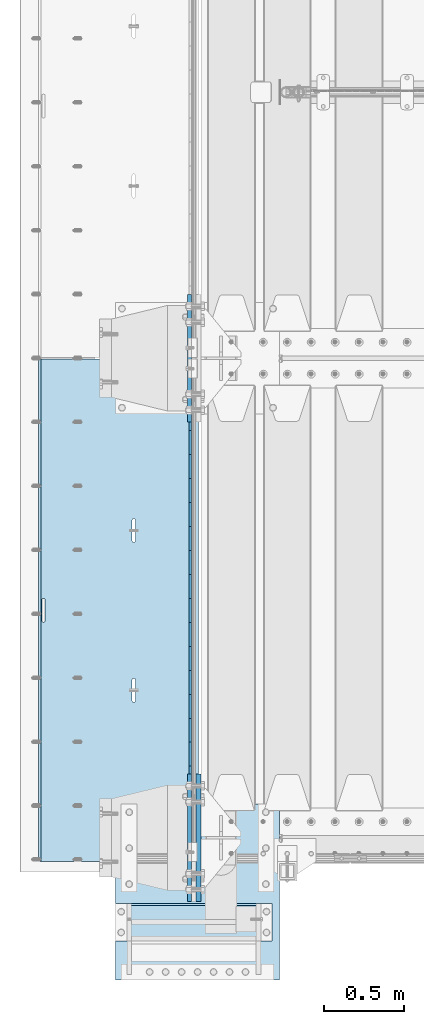
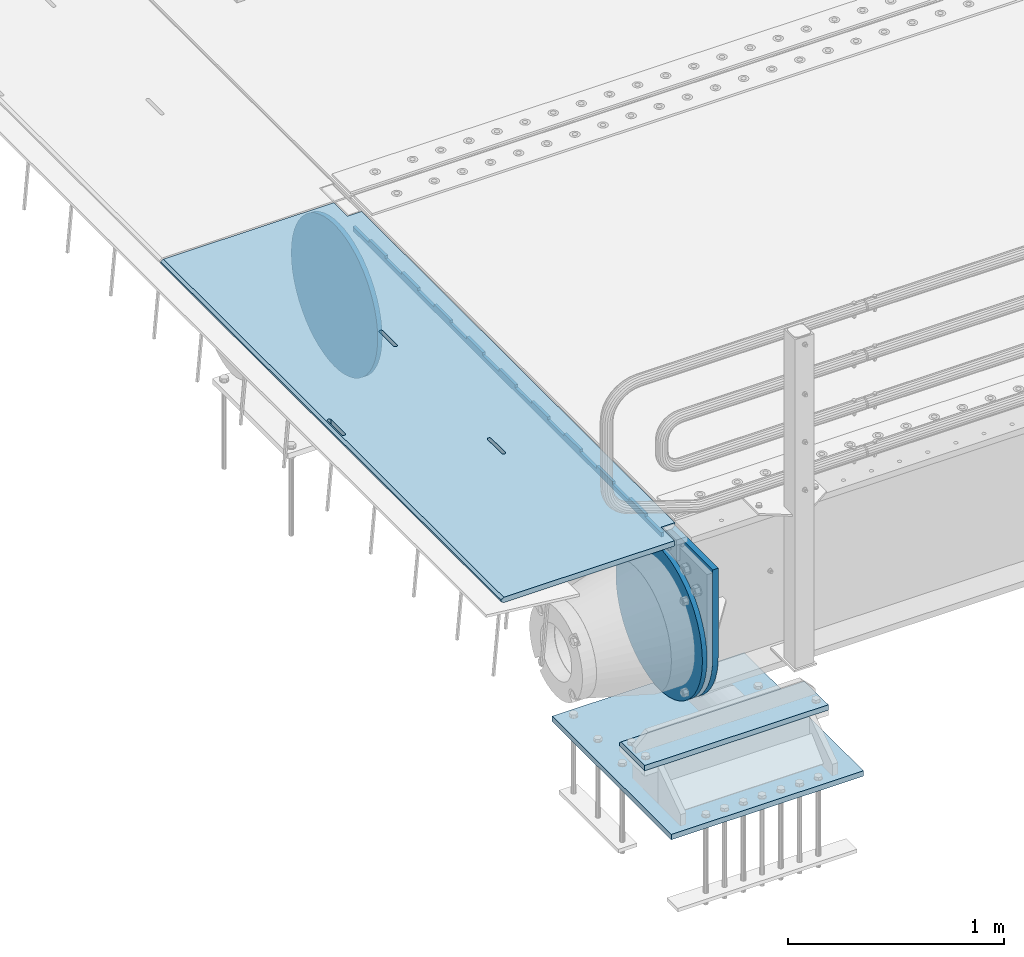
# One storey, part 190 of 242: 7 plates.
"""IFC2X3 building model written with IfcOpenShell, lengths in millimetres."""

from ifc_helpers import new_model, si_unit, frame, origin_with_axes, place, context, subcontext, project, spatial, faceted_brep, material, type_object, element, save


model = new_model("IFC2X3")

# Units and contexts
model_context = context("Model", 3, precision=1e-05, world=origin_with_axes())
body_context = subcontext(model_context, "Body", "Model", "MODEL_VIEW")
ifc_project = project(units=[si_unit("LENGTHUNIT", "METRE", prefix="MILLI"), si_unit("AREAUNIT", "SQUARE_METRE"), si_unit("VOLUMEUNIT", "CUBIC_METRE"), si_unit("MASSUNIT", "GRAM", prefix="KILO"), si_unit("TIMEUNIT", "SECOND"), si_unit("PLANEANGLEUNIT", "RADIAN"), si_unit("SOLIDANGLEUNIT", "STERADIAN"), si_unit("THERMODYNAMICTEMPERATUREUNIT", "DEGREE_CELSIUS"), si_unit("LUMINOUSINTENSITYUNIT", "LUMEN")], contexts=[model_context])

# Site, building, storey
site_placement = place(None, origin_with_axes())
site = spatial("IfcSite", under=ifc_project, at=site_placement, CompositionType="ELEMENT")
building_placement = place(site_placement, origin_with_axes())
building = spatial("IfcBuilding", under=site, at=building_placement, Name="Standard", CompositionType="ELEMENT")
storey_placement = place(building_placement, origin_with_axes())
storey = spatial("IfcBuildingStorey", under=building, at=storey_placement, Name="Undefined", CompositionType="ELEMENT", Elevation=0.0)

# Plates
ifc_material_1 = material(Name="STEEL/S355N")
plate_type_1 = type_object("IfcPlateType", PredefinedType="NOTDEFINED")
plate_1_placement = place(storey_placement, frame((-42455.0037545707, -21005.0000738707, -0.984410850183148), z_axis=(1.0000003385235e-09, -0.999999999987744, -4.95099999993936e-06), x_axis=(-0.999999999879068, -1.00000022173606e-09, -1.55519999981193e-05)))
element("IfcPlate", 1, at=plate_1_placement, inside=storey, type_object=plate_type_1, material=ifc_material_1, context=body_context, shape_type="Brep", body=[
    faceted_brep([(984.99645996136, -15.0, 3.63797880709171e-12), (999.996459960938, -4.99999999999848, 0.0), (999.996459718786, -4.99999999999849, 3145.0), (984.996459719208, -15.0, 3145.0), (999.996459960938, 5.0, 0.0), (984.996459960945, 15.0, 3.63797880709171e-12), (984.996459718794, 15.0, 3145.0), (999.996459718786, 5.0, 3145.0), (14.9998601691696, 15.0, 125.000024820823), (-0.000294611323624849, -0.000806902962788264, 124.999936248623), (-0.00191941575758392, 0.000806844426834791, 3020.00000492302), (14.9966216875182, 15.0, 3020.00007976651), (394.996621756989, -15.0000000032171, 2137.49999999762), (394.996621756989, 15.0, 2137.49999999762), (395.4860565938, 15.0, 2140.59016994137), (395.4860565938, -15.0000000032097, 2140.59016994137), (396.906451812785, 15.0, 2143.37785252055), (396.906451812785, -15.0000000031847, 2143.37785252055), (399.118769233435, 15.0, 2145.59016994137), (399.118769233435, -15.0000000031445, 2145.59016994137), (401.906451812501, 15.0, 2147.01056516057), (401.906451812509, -15.0000000030931, 2147.01056516058), (404.996621756211, 15.0, 2147.49999999762), (404.996621756211, -15.0000000030354, 2147.49999999762), (408.0867917, 15.0, 2147.01056516057), (408.0867917, -15.0000000029771, 2147.01056516058), (410.874474279284, 15.0, 2145.59016994137), (410.874474279277, -15.000000002924, 2145.59016994137), (413.086791700283, 15.0, 2143.37785252055), (413.086791700283, -15.0000000028812, 2143.37785252055), (414.507186919691, 15.0, 2140.59016994136), (414.507186919698, -15.0000000028529, 2140.59016994136), (414.996621756974, 15.0, 2137.49999999761), (414.996621756974, -15.000000002842, 2137.49999999761), (414.996621766892, 15.0, 2007.49999999761), (414.996621766892, -15.0000000027658, 2007.49999999761), (414.507186930081, 15.0, 2004.40983005386), (414.507186930088, -15.0000000027732, 2004.40983005387), (413.086791711095, 15.0, 2001.62214747469), (413.086791711088, -15.0000000027982, 2001.6221474747), (410.874474290446, 15.0, 1999.40983005387), (410.874474290438, -15.0000000028384, 1999.40983005387), (408.086791711372, 15.0, 1997.98943483467), (408.086791711372, -15.0000000028898, 1997.98943483467), (404.996621767779, 15.0, 1997.49999999762), (404.996621767779, -15.0000000029475, 1997.49999999762), (401.906451823983, 15.0, 1997.98943483467), (401.90645182399, -15.0000000030057, 1997.98943483468), (399.118769244706, 15.0, 1999.40983005387), (399.118769244713, -15.0000000030589, 1999.40983005387), (396.906451823714, 15.0, 2001.6221474747), (396.906451823714, -15.0000000031016, 2001.6221474747), (395.486056604299, 15.0, 2004.40983005387), (395.486056604299, -15.0000000031299, 2004.40983005387), (394.996621767008, 15.0, 2007.49999999762), (394.996621767008, -15.0000000031409, 2007.49999999762), (-0.000449375176685862, -14.9999999951863, 124.999861417735), (-0.000460362061858177, -15.00000004538, 3019.99993008589), (75.0001087167111, 15.0, 125.000079754092), (74.9996421867036, -15.0, 124.999930084094), (74.9997820616045, -15.0, 3.63797880709171e-12), (75.0002485915975, 15.0, 0.0), (74.9967306510152, 15.0, 3145.0), (74.9962640910162, -15.0, 3145.0), (74.9968705259016, 15.0, 3020.0000798241), (74.9964039659026, -14.999999998652, 3019.9999301541), (395.486056681293, -14.9999999992789, 1004.40983005436), (395.486056681293, 15.0, 1004.40983005435), (394.99662184401, 15.0, 1007.4999999981), (394.99662184401, -14.999999999278, 1007.49999999811), (396.906451900715, -14.999999999282, 1001.62214747518), (396.906451900715, 15.0, 1001.62214747518), (399.118769321707, -14.9999999992871, 999.409830054356), (399.1187693217, 15.0, 999.409830054356), (401.906451900999, -14.9999999992934, 997.989434835155), (401.906451900992, 15.0, 997.989434835155), (404.996621844781, -14.9999999993006, 997.499999998108), (404.996621844781, 15.0, 997.499999998108), (408.086791788373, -14.9999999993078, 997.989434835155), (408.086791788373, 15.0, 997.989434835152), (410.87447436744, -14.9999999993143, 999.409830054356), (410.87447436744, 15.0, 999.409830054356), (413.086791788097, -14.9999999993196, 1001.62214747518), (413.086791788097, 15.0, 1001.62214747518), (414.50718700709, -14.999999999323, 1004.40983005435), (414.507187007082, 15.0, 1004.40983005435), (414.996621843893, -14.9999999993243, 1007.4999999981), (414.996621843893, 15.0, 1007.4999999981), (414.996621833976, -14.9999999993318, 1137.4999999981), (414.996621833976, 15.0, 1137.49999999809), (414.507186996707, -14.9999999993308, 1140.59016994185), (414.5071869967, 15.0, 1140.59016994185), (413.086791777278, -14.9999999993277, 1143.37785252103), (413.086791777278, 15.0, 1143.37785252103), (410.874474356286, -14.9999999993227, 1145.59016994186), (410.874474356286, 15.0, 1145.59016994186), (408.086791776994, -14.9999999993163, 1147.01056516106), (408.086791776994, 15.0, 1147.01056516106), (404.996621833212, -14.9999999993092, 1147.49999999811), (404.996621833212, 15.0, 1147.4999999981), (401.90645188951, -14.999999999302, 1147.01056516106), (401.906451889503, 15.0, 1147.01056516106), (399.118769310437, -14.9999999992955, 1145.59016994186), (399.118769310437, 15.0, 1145.59016994186), (396.906451889779, -14.9999999992902, 1143.37785252103), (396.906451889779, 15.0, 1143.37785252103), (395.486056670801, -14.9999999992867, 1140.59016994185), (395.486056670808, 15.0, 1140.59016994185), (394.996621833991, -14.9999999992854, 1137.49999999811), (394.996621833998, 15.0, 1137.4999999981), (960.486056632304, -15.0000000006253, 1640.5901699416), (961.90645185129, -15.0000000006287, 1643.37785252078), (964.118769271947, -15.000000000634, 1645.5901699416), (966.906451851013, -15.0000000006405, 1647.0105651608), (969.996621794708, -15.0000000006477, 1647.49999999785), (973.086791738504, -15.0000000006549, 1647.01056516081), (975.874474317789, -15.0000000006612, 1645.5901699416), (978.086791738788, -15.0000000006662, 1643.37785252077), (979.50718695821, -15.0000000006694, 1640.5901699416), (979.996621795486, -15.0000000006703, 1637.49999999784), (979.996621805403, -15.0000000006628, 1507.49999999784), (979.507186968593, -15.0000000006615, 1504.4098300541), (978.0867917496, -15.0000000006581, 1501.62214747492), (975.874474328943, -15.0000000006528, 1499.4098300541), (973.086791749884, -15.0000000006463, 1497.9894348349), (969.996621806284, -15.0000000006391, 1497.49999999785), (966.906451862502, -15.0000000006319, 1497.9894348349), (964.118769283217, -15.0000000006256, 1499.4098300541), (961.906451862218, -15.0000000006206, 1501.62214747493), (960.486056642803, -15.0000000006174, 1504.4098300541), (959.99662180552, -15.0000000006165, 1507.49999999785), (959.996621795493, -15.000000000624, 1637.49999999785), (961.906451862218, 15.0, 1501.62214747493), (960.486056642803, 15.0, 1504.4098300541), (964.11876928321, 15.0, 1499.4098300541), (966.906451862495, 15.0, 1497.9894348349), (969.996621806284, 15.0, 1497.49999999785), (973.086791749884, 15.0, 1497.9894348349), (975.874474328943, 15.0, 1499.4098300541), (978.0867917496, 15.0, 1501.62214747492), (979.507186968585, 15.0, 1504.4098300541), (979.996621805403, 15.0, 1507.49999999784), (979.996621795486, 15.0, 1637.49999999784), (979.507186958203, 15.0, 1640.5901699416), (978.086791738788, 15.0, 1643.37785252077), (975.874474317789, 15.0, 1645.5901699416), (973.086791738504, 15.0, 1647.01056516081), (969.996621794715, 15.0, 1647.49999999785), (966.906451851006, 15.0, 1647.0105651608), (964.118769271947, 15.0, 1645.5901699416), (961.90645185129, 15.0, 1643.37785252078), (960.486056632304, 15.0, 1640.5901699416), (959.996621795493, 15.0, 1637.49999999785), (959.99662180552, 15.0, 1507.49999999785)], [[[0, 1, 2, 3]], [[4, 5, 6, 7]], [[8, 9, 10, 11]], [[12, 13, 14, 15]], [[15, 14, 16, 17]], [[17, 16, 18, 19]], [[19, 18, 20, 21]], [[21, 20, 22, 23]], [[23, 22, 24, 25]], [[25, 24, 26, 27]], [[27, 26, 28, 29]], [[29, 28, 30, 31]], [[31, 30, 32, 33]], [[33, 32, 34, 35]], [[35, 34, 36, 37]], [[37, 36, 38, 39]], [[39, 38, 40, 41]], [[41, 40, 42, 43]], [[43, 42, 44, 45]], [[45, 44, 46, 47]], [[47, 46, 48, 49]], [[49, 48, 50, 51]], [[51, 50, 52, 53]], [[53, 52, 54, 55]], [[55, 54, 13, 12]], [[56, 57, 10, 9]], [[58, 59, 56, 9, 8]], [[60, 59, 58, 61]], [[60, 61, 5, 4, 1, 0]], [[4, 7, 2, 1]], [[7, 6, 62, 63, 3, 2]], [[63, 62, 64, 65]], [[57, 65, 64, 11, 10]], [[66, 67, 68, 69]], [[70, 71, 67, 66]], [[72, 73, 71, 70]], [[74, 75, 73, 72]], [[76, 77, 75, 74]], [[78, 79, 77, 76]], [[80, 81, 79, 78]], [[82, 83, 81, 80]], [[84, 85, 83, 82]], [[86, 87, 85, 84]], [[88, 89, 87, 86]], [[90, 91, 89, 88]], [[92, 93, 91, 90]], [[94, 95, 93, 92]], [[96, 97, 95, 94]], [[98, 99, 97, 96]], [[100, 101, 99, 98]], [[102, 103, 101, 100]], [[104, 105, 103, 102]], [[106, 107, 105, 104]], [[108, 109, 107, 106]], [[69, 68, 109, 108]], [[63, 65, 57, 56, 59, 60, 0, 3], [15, 17, 19, 21, 23, 25, 27, 29, 31, 33, 35, 37, 39, 41, 43, 45, 47, 49, 51, 53, 55, 12], [106, 104, 102, 100, 98, 96, 94, 92, 90, 88, 86, 84, 82, 80, 78, 76, 74, 72, 70, 66, 69, 108], [110, 111, 112, 113, 114, 115, 116, 117, 118, 119, 120, 121, 122, 123, 124, 125, 126, 127, 128, 129, 130, 131]], [[128, 132, 133, 129]], [[127, 134, 132, 128]], [[126, 135, 134, 127]], [[125, 136, 135, 126]], [[124, 137, 136, 125]], [[123, 138, 137, 124]], [[122, 139, 138, 123]], [[121, 140, 139, 122]], [[120, 141, 140, 121]], [[119, 142, 141, 120]], [[118, 143, 142, 119]], [[117, 144, 143, 118]], [[116, 145, 144, 117]], [[115, 146, 145, 116]], [[114, 147, 146, 115]], [[113, 148, 147, 114]], [[112, 149, 148, 113]], [[111, 150, 149, 112]], [[110, 151, 150, 111]], [[131, 152, 151, 110]], [[130, 153, 152, 131]], [[129, 133, 153, 130]], [[61, 58, 8, 11, 64, 62, 6, 5], [50, 48, 46, 44, 42, 40, 38, 36, 34, 32, 30, 28, 26, 24, 22, 20, 18, 16, 14, 13, 54, 52], [132, 134, 135, 136, 137, 138, 139, 140, 141, 142, 143, 144, 145, 146, 147, 148, 149, 150, 151, 152, 153, 133], [71, 73, 75, 77, 79, 81, 83, 85, 87, 89, 91, 93, 95, 97, 99, 101, 103, 105, 107, 109, 68, 67]]]),
])
plate_type_2 = type_object("IfcPlateType", PredefinedType="NOTDEFINED")
plate_2_placement = place(storey_placement, frame((-42507.5, -21152.4999006275, -35.9858217390411), z_axis=(1.0000003385235e-09, -0.999999999987744, -4.95099999993936e-06), x_axis=(0.0, 4.95100000930962e-06, -0.999999999987744)))
element("IfcPlate", 2, at=plate_2_placement, inside=storey, type_object=plate_type_2, material=ifc_material_1, context=body_context, shape_type="Brep", body=[
    faceted_brep([(-7.105427357601e-15, -7.5, 3.63797880709171e-12), (8.68283223098842e-12, -7.5, 150.000000000004), (8.68283223098842e-12, 7.5, 150.000000000004), (-7.105427357601e-15, 7.5, 3.63797880709171e-12), (-14.9999999999986, -7.5, 150.0), (-14.9999999999986, 7.5, 150.0), (-14.9999999999972, -7.5, 300.000000000004), (-14.9999999999972, 7.5, 300.000000000004), (1.55324642037158e-11, -7.5, 300.000000000004), (1.55324642037158e-11, 7.5, 300.000000000004), (1.87654336514242e-11, -7.5, 450.000000000004), (1.87654336514242e-11, 7.5, 450.000000000004), (-14.9999999999958, -7.5, 450.000000000004), (-14.9999999999958, 7.5, 450.000000000004), (-14.9999999999944, -7.5, 600.0), (-14.9999999999944, 7.5, 600.0), (2.74411604550551e-11, -7.5, 600.000000000004), (2.74411604550551e-11, 7.5, 600.000000000004), (3.24860138789518e-11, -7.5, 750.000000000004), (3.24860138789518e-11, 7.5, 750.000000000004), (-14.999999999993, -7.5, 750.000000000004), (-14.999999999993, 7.5, 750.000000000004), (-14.9999999999916, -7.5, 900.000000000007), (-14.9999999999916, 7.5, 900.000000000007), (4.11688461099402e-11, -7.5, 900.000000000004), (4.11688461099402e-11, 7.5, 900.000000000004), (4.62136995338369e-11, -7.5, 1050.0), (4.62136995338369e-11, 7.5, 1050.0), (-14.9999999999902, -7.5, 1050.0), (-14.9999999999902, 7.5, 1050.0), (-14.9999999999888, -7.5, 1200.0), (-14.9999999999888, 7.5, 1200.0), (5.30775423612795e-11, -7.5, 1200.0), (5.30775423612795e-11, 7.5, 1200.0), (5.99413851887221e-11, -7.5, 1350.0), (5.99413851887221e-11, 7.5, 1350.0), (-14.9999999999874, -7.5, 1350.00000000001), (-14.9999999999874, 7.5, 1350.00000000001), (-14.9999999999859, -7.5, 1500.0), (-14.9999999999859, 7.5, 1500.0), (6.49791331852612e-11, -7.5, 1500.0), (6.49791331852612e-11, 7.5, 1500.0), (7.36690708436072e-11, -7.5, 1650.0), (7.36690708436072e-11, 7.5, 1650.0), (-14.9999999999845, -7.5, 1650.0), (-14.9999999999845, 7.5, 1650.0), (-14.9999999999831, -7.5, 1800.00000000001), (-14.9999999999831, 7.5, 1800.00000000001), (7.68878294366004e-11, -7.5, 1800.0), (7.68878294366004e-11, 7.5, 1800.0), (8.3751672264043e-11, -7.5, 1950.0), (8.3751672264043e-11, 7.5, 1950.0), (-14.9999999999817, -7.5, 1950.0), (-14.9999999999817, 7.5, 1950.0), (-14.9999999999803, -7.5, 2100.0), (-14.9999999999803, 7.5, 2100.0), (9.06226205188432e-11, -7.5, 2100.0), (9.06226205188432e-11, 7.5, 2100.0), (9.56603685153823e-11, -7.5, 2250.00000000001), (9.56603685153823e-11, 7.5, 2250.00000000001), (-14.9999999999789, -7.5, 2250.00000000001), (-14.9999999999789, 7.5, 2250.00000000001), (-14.9999999999775, -7.5, 2400.0), (-14.9999999999775, 7.5, 2400.0), (1.04343200746371e-10, -7.5, 2400.0), (1.04343200746371e-10, 7.5, 2400.0), (1.0938094874291e-10, -7.5, 2550.0), (1.0938094874291e-10, 7.5, 2550.0), (-14.9999999999761, -7.5, 2550.0), (-14.9999999999761, 7.5, 2550.0), (-14.9999999999747, -7.5, 2700.00000000001), (-14.9999999999747, 7.5, 2700.00000000001), (1.14432907594164e-10, -7.5, 2700.00000000001), (1.14432907594164e-10, 7.5, 2700.00000000001), (1.23108634397795e-10, -7.5, 2850.0), (1.23108634397795e-10, 7.5, 2850.0), (25.0000000000267, -7.5, 2850.0), (25.0000000000267, 7.5, 2850.0), (25.0, -7.5, 3.63797880709171e-12), (25.0, 7.5, 3.63797880709171e-12)], [[[0, 1, 2, 3]], [[1, 4, 5, 2]], [[4, 6, 7, 5]], [[6, 8, 9, 7]], [[8, 10, 11, 9]], [[10, 12, 13, 11]], [[12, 14, 15, 13]], [[14, 16, 17, 15]], [[16, 18, 19, 17]], [[18, 20, 21, 19]], [[20, 22, 23, 21]], [[22, 24, 25, 23]], [[24, 26, 27, 25]], [[26, 28, 29, 27]], [[28, 30, 31, 29]], [[30, 32, 33, 31]], [[32, 34, 35, 33]], [[34, 36, 37, 35]], [[36, 38, 39, 37]], [[38, 40, 41, 39]], [[40, 42, 43, 41]], [[42, 44, 45, 43]], [[44, 46, 47, 45]], [[46, 48, 49, 47]], [[48, 50, 51, 49]], [[50, 52, 53, 51]], [[52, 54, 55, 53]], [[54, 56, 57, 55]], [[56, 58, 59, 57]], [[58, 60, 61, 59]], [[60, 62, 63, 61]], [[62, 64, 65, 63]], [[64, 66, 67, 65]], [[66, 68, 69, 67]], [[68, 70, 71, 69]], [[70, 72, 73, 71]], [[72, 74, 75, 73]], [[74, 76, 77, 75]], [[76, 78, 79, 77]], [[78, 0, 3, 79]], [[5, 7, 9, 11, 13, 15, 17, 19, 21, 23, 25, 27, 29, 31, 33, 35, 37, 39, 41, 43, 45, 47, 49, 51, 53, 55, 57, 59, 61, 63, 65, 67, 69, 71, 73, 75, 77, 79, 3, 2]], [[78, 76, 74, 72, 70, 68, 66, 64, 62, 60, 58, 56, 54, 52, 50, 48, 46, 44, 42, 40, 38, 36, 34, 32, 30, 28, 26, 24, 22, 20, 18, 16, 14, 12, 10, 8, 6, 4, 1, 0]]]),
])
plate_type_3 = type_object("IfcPlateType", PredefinedType="NOTDEFINED")
plate_3_placement = place(storey_placement, frame((-42455.0, -24400.0, -20.0), z_axis=(0.0, 1.0, 0.0), x_axis=(0.0, 0.0, -1.0)))
element("IfcPlate", 3, at=plate_3_placement, inside=storey, type_object=plate_type_3, material=ifc_material_1, context=body_context, shape_type="Brep", body=[
    faceted_brep([(855.0, -15.0, 572.963114670041), (855.0, 15.0, 572.963114670041), (849.182410260924, 15.0, 585.889268816907), (849.182410260924, -15.0, 585.889268816907), (824.193546357181, 15.0, 627.22589869189), (824.193546357181, -15.0, 627.22589869189), (794.404299268241, 15.0, 665.249063295789), (794.404299268241, -15.0, 665.249063295789), (760.249063296205, 15.0, 699.404299267968), (760.249063296205, -15.0, 699.404299267968), (722.225898692439, 15.0, 729.193546357052), (722.225898692439, -15.0, 729.193546357052), (680.889268817575, 15.0, 754.182410260939), (680.889268817575, -15.0, 754.182410260939), (636.841954817181, 15.0, 774.006497073897), (636.841954817181, -15.0, 774.006497073897), (590.726265715288, 15.0, 788.376726970229), (590.726265715288, -15.0, 788.376726970229), (543.214672102496, 15.0, 797.083549639108), (543.214672102496, -15.0, 797.083549639108), (495.0, -15.0, 800.000000000029), (495.0, 15.0, 800.0), (494.999999999412, -15.0, 0.0), (494.999999999412, 15.0, 0.0), (543.21467210319, 15.0, 2.91645036481714), (543.21467210319, -15.0, 2.91645036481714), (590.726265715857, 15.0, 11.6232730332849), (590.726265715857, -15.0, 11.6232730332849), (636.841954817646, 15.0, 25.9935029291846), (636.841954817646, -15.0, 25.9935029291846), (680.889268817962, 15.0, 45.817589741695), (680.889268817962, -15.0, 45.817589741695), (722.225898692766, 15.0, 70.8064536451311), (722.225898692766, -15.0, 70.8064536451311), (760.249063296498, 15.0, 100.595700733757), (760.249063296498, -15.0, 100.595700733757), (794.404299268526, 15.0, 134.750936705481), (794.404299268526, -15.0, 134.750936705481), (824.193546357479, 15.0, 172.77410130894), (824.193546357479, -15.0, 172.77410130894), (849.182410261259, 15.0, 214.110731183497), (849.182410261259, -15.0, 214.110731183497), (855.0, -15.0, 227.03688532946), (855.0, 15.0, 227.03688532946), (0.0, -15.0, 0.0), (0.0, 15.0, 0.0), (0.0, 15.0, 800.0), (0.0, -15.0, 800.0)], [[[0, 1, 2, 3]], [[3, 2, 4, 5]], [[5, 4, 6, 7]], [[7, 6, 8, 9]], [[9, 8, 10, 11]], [[11, 10, 12, 13]], [[13, 12, 14, 15]], [[15, 14, 16, 17]], [[17, 16, 18, 19]], [[20, 19, 18, 21]], [[22, 23, 24, 25]], [[25, 24, 26, 27]], [[27, 26, 28, 29]], [[29, 28, 30, 31]], [[31, 30, 32, 33]], [[33, 32, 34, 35]], [[35, 34, 36, 37]], [[37, 36, 38, 39]], [[39, 38, 40, 41]], [[42, 41, 40, 43]], [[42, 43, 1, 0]], [[44, 45, 23, 22]], [[16, 14, 12, 10, 8, 6, 4, 2, 1, 43, 40, 38, 36, 34, 32, 30, 28, 26, 24, 23, 45, 46, 21, 18]], [[44, 47, 46, 45]], [[46, 47, 20, 21]], [[47, 44, 22, 25, 27, 29, 31, 33, 35, 37, 39, 41, 42, 0, 3, 5, 7, 9, 11, 13, 15, 17, 19, 20]]]),
])
plate_type_4 = type_object("IfcPlateType", PredefinedType="NOTDEFINED")
plate_4_placement = place(storey_placement, frame((-42512.5, -20600.0, -114.999999999998), z_axis=(0.0, 0.0, -1.0), x_axis=(0.0, -1.0, 0.0)))
element("IfcPlate", 4, at=plate_4_placement, inside=storey, type_object=plate_type_4, material=ifc_material_1, context=body_context, shape_type="Brep", body=[
    faceted_brep([(0.0, -12.5, 400.0), (2.91645036199043, -12.5, 448.214672101509), (2.91645036199043, 12.5, 448.214672101509), (0.0, 12.5, 400.0), (11.6232730309493, -12.5, 495.726265714256), (11.6232730309493, 12.5, 495.726265714256), (25.9935029273402, -12.5, 541.841954816098), (25.9935029273402, 12.5, 541.841954816098), (45.8175897403271, -12.5, 585.889268816447), (45.8175897403271, 12.5, 585.889268816447), (70.8064536442362, -12.5, 627.225898691268), (70.8064536442362, 12.5, 627.225898691268), (100.595700733313, -12.5, 665.249063295001), (100.595700733313, 12.5, 665.249063295001), (134.75093670547, -12.5, 699.404299267018), (134.75093670547, 12.5, 699.404299267018), (172.774101309336, -12.5, 729.193546355957), (172.774101309336, 12.5, 729.193546355957), (214.110731184279, -12.5, 754.182410259717), (214.110731184279, 12.5, 754.182410259717), (258.158045184744, -12.5, 774.006497072562), (258.158045184744, 12.5, 774.006497072562), (304.273734286689, -12.5, 788.376726968807), (304.273734286689, 12.5, 788.376726968807), (351.785327899524, -12.5, 797.083549637626), (351.785327899524, 12.5, 797.083549637626), (400.0, -12.5, 800.0), (400.0, 12.5, 800.0), (448.214672103393, -12.5, 797.083549638417), (448.214672103393, 12.5, 797.083549638417), (495.726265716065, -12.5, 788.376726969676), (495.726265716065, 12.5, 788.376726969676), (541.841954817828, -12.5, 774.006497073487), (541.841954817828, 12.5, 774.006497073487), (585.889268818089, -12.5, 754.182410260677), (585.889268818089, 12.5, 754.182410260677), (627.225898692814, -12.5, 729.193546356937), (627.225898692814, 12.5, 729.193546356937), (665.249063296429, -12.5, 699.404299268004), (665.249063296429, 12.5, 699.404299268004), (699.404299268321, -12.5, 665.249063295974), (699.404299268321, 12.5, 665.249063295974), (729.19354635711, -12.5, 627.225898692221), (729.19354635711, 12.5, 627.225898692221), (754.182410260706, -12.5, 585.889268817375), (754.182410260706, 12.5, 585.889268817375), (774.006497073366, -12.5, 541.841954817), (774.006497073366, 12.5, 541.841954817), (788.376726969411, -12.5, 495.726265715133), (788.376726969411, 12.5, 495.726265715133), (797.08354963801, -12.5, 448.214672102373), (797.08354963801, 12.5, 448.214672102373), (800.0, -12.5, 400.0), (800.0, 12.5, 400.0), (797.08354963802, -12.5, 351.785327898509), (797.08354963802, 12.5, 351.785327898509), (788.376726969058, -12.5, 304.273734285764), (788.376726969058, 12.5, 304.273734285764), (774.006497072671, -12.5, 258.158045183922), (774.006497072671, 12.5, 258.158045183922), (754.18241025968, -12.5, 214.110731183573), (754.18241025968, 12.5, 214.110731183573), (729.193546355775, -12.5, 172.774101308758), (729.193546355775, 12.5, 172.774101308758), (699.404299266695, -12.5, 134.750936705022), (699.404299266695, 12.5, 134.750936705022), (665.249063294537, -12.5, 100.595700733011), (665.249063294537, 12.5, 100.595700733011), (627.225898690671, -12.5, 70.8064536440761), (627.225898690671, 12.5, 70.8064536440761), (585.889268815728, -12.5, 45.817589740318), (585.889268815728, 12.5, 45.817589740318), (541.841954815267, -12.5, 25.9935029274748), (541.841954815267, 12.5, 25.9935029274748), (495.726265713321, -12.5, 11.6232730312331), (495.726265713321, 12.5, 11.6232730312331), (448.214672100487, -12.5, 2.91645036241607), (448.214672100487, 12.5, 2.91645036241607), (400.0, -12.5, -5.6843418860808e-14), (400.0, 12.5, -5.6843418860808e-14), (351.785327896621, -12.5, 2.91645036159753), (351.785327896621, 12.5, 2.91645036159753), (304.27373428395, -12.5, 11.6232730303418), (304.27373428395, 12.5, 11.6232730303418), (258.15804518219, -12.5, 25.9935029265289), (258.15804518219, 12.5, 25.9935029265289), (214.110731181929, -12.5, 45.8175897393394), (214.110731181929, 12.5, 45.8175897393394), (172.774101307208, -12.5, 70.8064536430811), (172.774101307208, 12.5, 70.8064536430811), (134.750936703589, -12.5, 100.595700732014), (134.750936703589, 12.5, 100.595700732014), (100.595700731697, -12.5, 134.750936704046), (100.595700731697, 12.5, 134.750936704046), (70.8064536429083, -12.5, 172.774101307798), (70.8064536429083, 12.5, 172.774101307798), (45.8175897393157, -12.5, 214.11073118264), (45.8175897393157, 12.5, 214.11073118264), (25.9935029266562, -12.5, 258.158045183016), (25.9935029266562, 12.5, 258.158045183016), (11.623273030611, -12.5, 304.273734284881), (11.623273030611, 12.5, 304.273734284881), (2.91645036201226, -12.5, 351.785327897642), (2.91645036201226, 12.5, 351.785327897642)], [[[0, 1, 2, 3]], [[1, 4, 5, 2]], [[4, 6, 7, 5]], [[6, 8, 9, 7]], [[8, 10, 11, 9]], [[10, 12, 13, 11]], [[12, 14, 15, 13]], [[14, 16, 17, 15]], [[16, 18, 19, 17]], [[18, 20, 21, 19]], [[20, 22, 23, 21]], [[22, 24, 25, 23]], [[24, 26, 27, 25]], [[26, 28, 29, 27]], [[28, 30, 31, 29]], [[30, 32, 33, 31]], [[32, 34, 35, 33]], [[34, 36, 37, 35]], [[36, 38, 39, 37]], [[38, 40, 41, 39]], [[40, 42, 43, 41]], [[42, 44, 45, 43]], [[44, 46, 47, 45]], [[46, 48, 49, 47]], [[48, 50, 51, 49]], [[50, 52, 53, 51]], [[52, 54, 55, 53]], [[54, 56, 57, 55]], [[56, 58, 59, 57]], [[58, 60, 61, 59]], [[60, 62, 63, 61]], [[62, 64, 65, 63]], [[64, 66, 67, 65]], [[66, 68, 69, 67]], [[68, 70, 71, 69]], [[70, 72, 73, 71]], [[72, 74, 75, 73]], [[74, 76, 77, 75]], [[76, 78, 79, 77]], [[78, 80, 81, 79]], [[80, 82, 83, 81]], [[82, 84, 85, 83]], [[84, 86, 87, 85]], [[86, 88, 89, 87]], [[88, 90, 91, 89]], [[90, 92, 93, 91]], [[92, 94, 95, 93]], [[94, 96, 97, 95]], [[96, 98, 99, 97]], [[98, 100, 101, 99]], [[100, 102, 103, 101]], [[102, 0, 3, 103]], [[5, 7, 9, 11, 13, 15, 17, 19, 21, 23, 25, 27, 29, 31, 33, 35, 37, 39, 41, 43, 45, 47, 49, 51, 53, 55, 57, 59, 61, 63, 65, 67, 69, 71, 73, 75, 77, 79, 81, 83, 85, 87, 89, 91, 93, 95, 97, 99, 101, 103, 3, 2]], [[102, 100, 98, 96, 94, 92, 90, 88, 86, 84, 82, 80, 78, 76, 74, 72, 70, 68, 66, 64, 62, 60, 58, 56, 54, 52, 50, 48, 46, 44, 42, 40, 38, 36, 34, 32, 30, 28, 26, 24, 22, 20, 18, 16, 14, 12, 10, 8, 6, 4, 1, 0]]]),
])
plate_5_placement = place(storey_placement, frame((-42512.5, -23600.0, -114.999999999998), z_axis=(0.0, 0.0, -1.0), x_axis=(0.0, -1.0, 0.0)))
element("IfcPlate", 5, at=plate_5_placement, inside=storey, type_object=plate_type_4, material=ifc_material_1, context=body_context, shape_type="Brep", body=[
    faceted_brep([(0.0, -12.5, 400.0), (2.91645036199043, -12.5, 448.214672101509), (2.91645036199043, 12.5, 448.214672101509), (0.0, 12.5, 400.0), (11.6232730309493, -12.5, 495.726265714256), (11.6232730309493, 12.5, 495.726265714256), (25.9935029273402, -12.5, 541.841954816098), (25.9935029273402, 12.5, 541.841954816098), (45.8175897403271, -12.5, 585.889268816447), (45.8175897403271, 12.5, 585.889268816447), (70.8064536442362, -12.5, 627.225898691268), (70.8064536442362, 12.5, 627.225898691268), (100.595700733313, -12.5, 665.249063295001), (100.595700733313, 12.5, 665.249063295001), (134.75093670547, -12.5, 699.404299267018), (134.75093670547, 12.5, 699.404299267018), (172.774101309336, -12.5, 729.193546355957), (172.774101309336, 12.5, 729.193546355957), (214.110731184279, -12.5, 754.182410259717), (214.110731184279, 12.5, 754.182410259717), (258.158045184744, -12.5, 774.006497072562), (258.158045184744, 12.5, 774.006497072562), (304.273734286689, -12.5, 788.376726968807), (304.273734286689, 12.5, 788.376726968807), (351.785327899524, -12.5, 797.083549637626), (351.785327899524, 12.5, 797.083549637626), (400.0, -12.5, 800.0), (400.0, 12.5, 800.0), (448.214672103393, -12.5, 797.083549638417), (448.214672103393, 12.5, 797.083549638417), (495.726265716065, -12.5, 788.376726969676), (495.726265716065, 12.5, 788.376726969676), (541.841954817828, -12.5, 774.006497073487), (541.841954817828, 12.5, 774.006497073487), (585.889268818089, -12.5, 754.182410260677), (585.889268818089, 12.5, 754.182410260677), (627.225898692814, -12.5, 729.193546356937), (627.225898692814, 12.5, 729.193546356937), (665.249063296429, -12.5, 699.404299268004), (665.249063296429, 12.5, 699.404299268004), (699.404299268321, -12.5, 665.249063295974), (699.404299268321, 12.5, 665.249063295974), (729.19354635711, -12.5, 627.225898692221), (729.19354635711, 12.5, 627.225898692221), (754.182410260706, -12.5, 585.889268817375), (754.182410260706, 12.5, 585.889268817375), (774.006497073366, -12.5, 541.841954817), (774.006497073366, 12.5, 541.841954817), (788.376726969411, -12.5, 495.726265715133), (788.376726969411, 12.5, 495.726265715133), (797.08354963801, -12.5, 448.214672102373), (797.08354963801, 12.5, 448.214672102373), (800.0, -12.5, 400.0), (800.0, 12.5, 400.0), (797.08354963802, -12.5, 351.785327898509), (797.08354963802, 12.5, 351.785327898509), (788.376726969058, -12.5, 304.273734285764), (788.376726969058, 12.5, 304.273734285764), (774.006497072671, -12.5, 258.158045183922), (774.006497072671, 12.5, 258.158045183922), (754.18241025968, -12.5, 214.110731183573), (754.18241025968, 12.5, 214.110731183573), (729.193546355775, -12.5, 172.774101308758), (729.193546355775, 12.5, 172.774101308758), (699.404299266695, -12.5, 134.750936705022), (699.404299266695, 12.5, 134.750936705022), (665.249063294537, -12.5, 100.595700733011), (665.249063294537, 12.5, 100.595700733011), (627.225898690671, -12.5, 70.8064536440761), (627.225898690671, 12.5, 70.8064536440761), (585.889268815728, -12.5, 45.817589740318), (585.889268815728, 12.5, 45.817589740318), (541.841954815267, -12.5, 25.9935029274748), (541.841954815267, 12.5, 25.9935029274748), (495.726265713321, -12.5, 11.6232730312331), (495.726265713321, 12.5, 11.6232730312331), (448.214672100487, -12.5, 2.91645036241607), (448.214672100487, 12.5, 2.91645036241607), (400.0, -12.5, -5.6843418860808e-14), (400.0, 12.5, -5.6843418860808e-14), (351.785327896621, -12.5, 2.91645036159753), (351.785327896621, 12.5, 2.91645036159753), (304.27373428395, -12.5, 11.6232730303418), (304.27373428395, 12.5, 11.6232730303418), (258.15804518219, -12.5, 25.9935029265289), (258.15804518219, 12.5, 25.9935029265289), (214.110731181929, -12.5, 45.8175897393394), (214.110731181929, 12.5, 45.8175897393394), (172.774101307208, -12.5, 70.8064536430811), (172.774101307208, 12.5, 70.8064536430811), (134.750936703589, -12.5, 100.595700732014), (134.750936703589, 12.5, 100.595700732014), (100.595700731697, -12.5, 134.750936704046), (100.595700731697, 12.5, 134.750936704046), (70.8064536429083, -12.5, 172.774101307798), (70.8064536429083, 12.5, 172.774101307798), (45.8175897393157, -12.5, 214.11073118264), (45.8175897393157, 12.5, 214.11073118264), (25.9935029266562, -12.5, 258.158045183016), (25.9935029266562, 12.5, 258.158045183016), (11.623273030611, -12.5, 304.273734284881), (11.623273030611, 12.5, 304.273734284881), (2.91645036201226, -12.5, 351.785327897642), (2.91645036201226, 12.5, 351.785327897642)], [[[0, 1, 2, 3]], [[1, 4, 5, 2]], [[4, 6, 7, 5]], [[6, 8, 9, 7]], [[8, 10, 11, 9]], [[10, 12, 13, 11]], [[12, 14, 15, 13]], [[14, 16, 17, 15]], [[16, 18, 19, 17]], [[18, 20, 21, 19]], [[20, 22, 23, 21]], [[22, 24, 25, 23]], [[24, 26, 27, 25]], [[26, 28, 29, 27]], [[28, 30, 31, 29]], [[30, 32, 33, 31]], [[32, 34, 35, 33]], [[34, 36, 37, 35]], [[36, 38, 39, 37]], [[38, 40, 41, 39]], [[40, 42, 43, 41]], [[42, 44, 45, 43]], [[44, 46, 47, 45]], [[46, 48, 49, 47]], [[48, 50, 51, 49]], [[50, 52, 53, 51]], [[52, 54, 55, 53]], [[54, 56, 57, 55]], [[56, 58, 59, 57]], [[58, 60, 61, 59]], [[60, 62, 63, 61]], [[62, 64, 65, 63]], [[64, 66, 67, 65]], [[66, 68, 69, 67]], [[68, 70, 71, 69]], [[70, 72, 73, 71]], [[72, 74, 75, 73]], [[74, 76, 77, 75]], [[76, 78, 79, 77]], [[78, 80, 81, 79]], [[80, 82, 83, 81]], [[82, 84, 85, 83]], [[84, 86, 87, 85]], [[86, 88, 89, 87]], [[88, 90, 91, 89]], [[90, 92, 93, 91]], [[92, 94, 95, 93]], [[94, 96, 97, 95]], [[96, 98, 99, 97]], [[98, 100, 101, 99]], [[100, 102, 103, 101]], [[102, 0, 3, 103]], [[5, 7, 9, 11, 13, 15, 17, 19, 21, 23, 25, 27, 29, 31, 33, 35, 37, 39, 41, 43, 45, 47, 49, 51, 53, 55, 57, 59, 61, 63, 65, 67, 69, 71, 73, 75, 77, 79, 81, 83, 85, 87, 89, 91, 93, 95, 97, 99, 101, 103, 3, 2]], [[102, 100, 98, 96, 94, 92, 90, 88, 86, 84, 82, 80, 78, 76, 74, 72, 70, 68, 66, 64, 62, 60, 58, 56, 54, 52, 50, 48, 46, 44, 42, 40, 38, 36, 34, 32, 30, 28, 26, 24, 22, 20, 18, 16, 14, 12, 10, 8, 6, 4, 1, 0]]]),
])
ifc_material_2 = material()
plate_type_5 = type_object("IfcPlateType", PredefinedType="NOTDEFINED")
plate_6_placement = place(storey_placement, frame((-41994.9999999991, -24644.9999999964, -813.000000000004), z_axis=(0.0, 1.0, 0.0), x_axis=(-1.0, 0.0, 0.0)))
element("IfcPlate", 6, at=plate_6_placement, inside=storey, type_object=plate_type_5, material=ifc_material_2, context=body_context, shape_type="Brep", body=[
    faceted_brep([(979.0, 0.0, 235.0), (979.0, 15.0, 220.0), (0.0, 15.0, 220.0), (0.0, 0.0, 235.0), (0.0, 15.0, 0.0), (0.0, -15.0, 0.0), (0.0, -15.0, 235.0), (979.0, -15.0, 235.0), (979.0, -15.0, 0.0), (979.0, 15.0, 0.0)], [[[0, 1, 2, 3]], [[4, 5, 6, 3, 2]], [[6, 7, 0, 3]], [[7, 8, 9, 1, 0]], [[8, 5, 4, 9]], [[9, 4, 2, 1]], [[8, 7, 6, 5]]]),
])
plate_type_6 = type_object("IfcPlateType", PredefinedType="NOTDEFINED")
plate_7_placement = place(storey_placement, frame((-42974.0, -24890.0, -1053.0), z_axis=(1.0, 0.0, 0.0), x_axis=(0.0, 1.0, 0.0)))
element("IfcPlate", 7, at=plate_7_placement, inside=storey, type_object=plate_type_6, material=ifc_material_2, context=body_context, shape_type="Brep", body=[
    faceted_brep([(0.0, -15.0, 0.0), (2.93249104288407e-06, -15.0, 1025.0), (2.93249104288407e-06, 15.0, 1025.0), (0.0, 15.0, 0.0), (1100.0, -15.0, 1025.0), (1100.0, 15.0, 1025.0), (1100.0, -15.0, -2.18278728425503e-11), (1100.0, 15.0, -2.18278728425503e-11)], [[[0, 1, 2, 3]], [[1, 4, 5, 2]], [[4, 6, 7, 5]], [[6, 0, 3, 7]], [[5, 7, 3, 2]], [[6, 4, 1, 0]]]),
])

save(model, "model.ifc")
